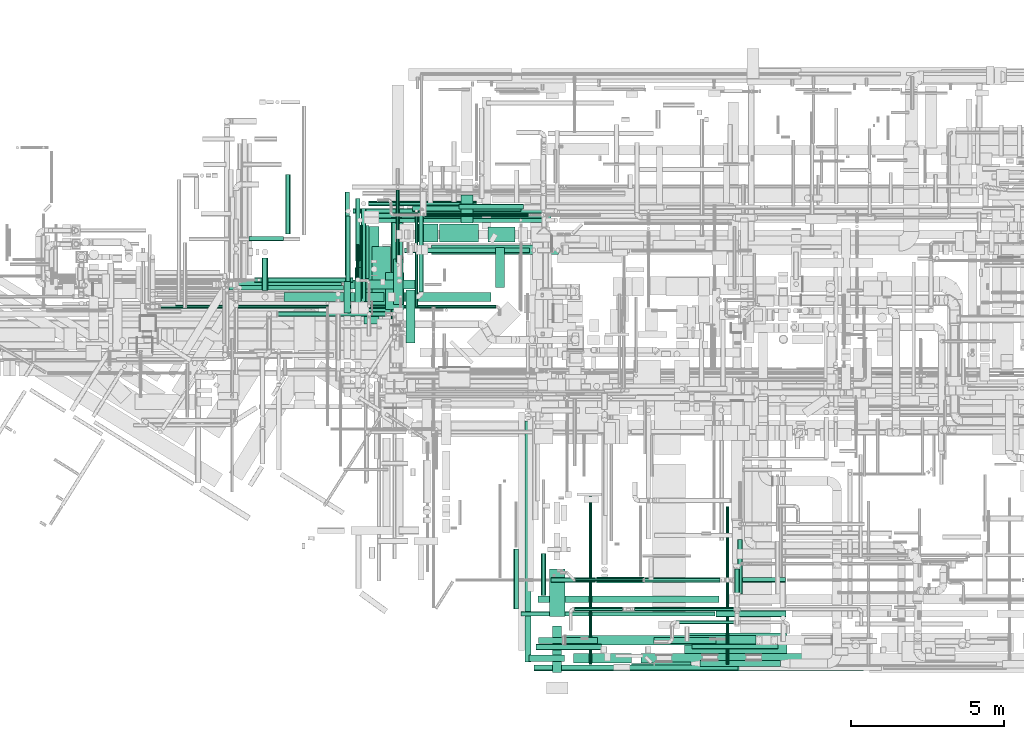
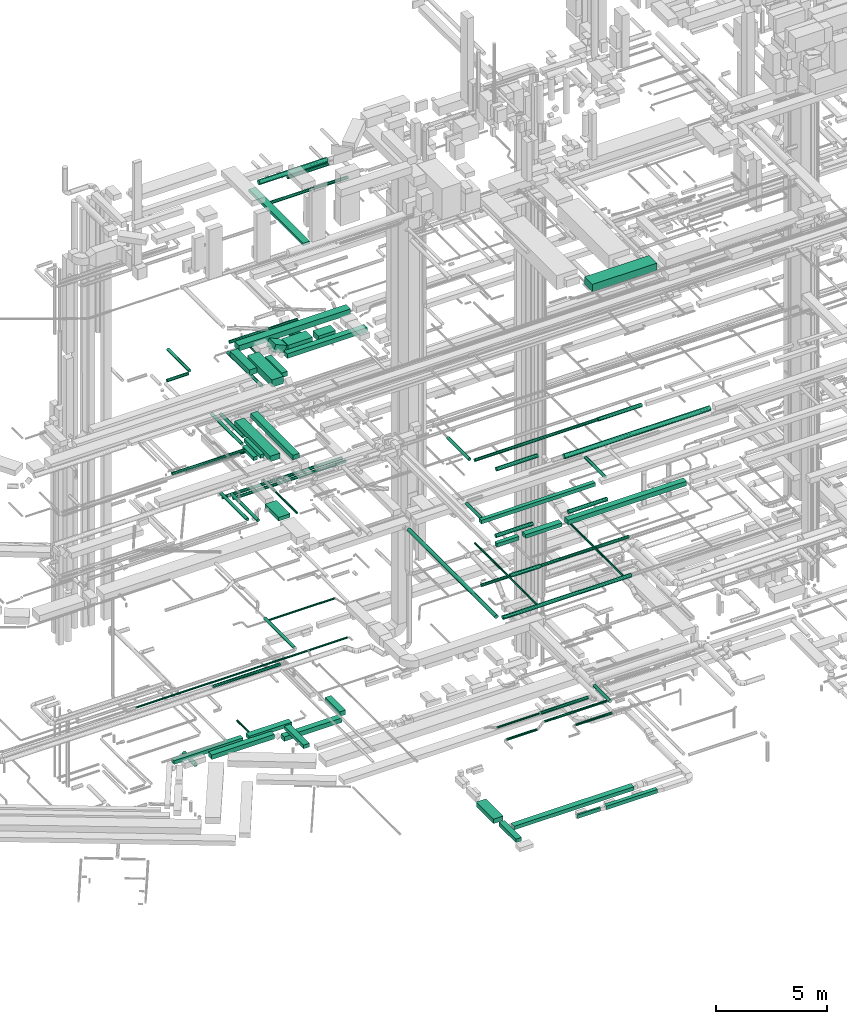
# One storey, part 29 of 337: 77 flow segments.
"""IFC2X3 building model written with IfcOpenShell, lengths in millimetres."""

from ifc_helpers import new_model, entity, si_unit, converted_unit, derived_unit, direction, frame, origin, origin_2d_with_axis, place, context, subcontext, project, spatial, rectangle, circle, extrude, type_object, element, save


model = new_model("IFC2X3")

# Units and contexts
model_context = context("Model", 3, precision=0.01, world=origin(), true_north=direction((6.12303176911189e-17, 1.0)))
body_context = subcontext(model_context, "Body", "Model", "MODEL_VIEW")
ifc_project = project(units=[si_unit("LENGTHUNIT", "METRE", prefix="MILLI"), si_unit("AREAUNIT", "SQUARE_METRE"), si_unit("VOLUMEUNIT", "CUBIC_METRE"), converted_unit("PLANEANGLEUNIT", "DEGREE", entity("IfcRatioMeasure", 0.0174532925199433), si_unit("PLANEANGLEUNIT", "RADIAN"), dimensions=[0, 0, 0, 0, 0, 0, 0]), si_unit("MASSUNIT", "GRAM", prefix="KILO"), derived_unit("MASSDENSITYUNIT", [(si_unit("MASSUNIT", "GRAM", prefix="KILO"), 1), (si_unit("LENGTHUNIT", "METRE"), -3)]), derived_unit("MOMENTOFINERTIAUNIT", [(si_unit("LENGTHUNIT", "METRE"), 4)]), si_unit("TIMEUNIT", "SECOND"), si_unit("FREQUENCYUNIT", "HERTZ"), si_unit("THERMODYNAMICTEMPERATUREUNIT", "DEGREE_CELSIUS"), derived_unit("THERMALTRANSMITTANCEUNIT", [(si_unit("MASSUNIT", "GRAM", prefix="KILO"), 1), (si_unit("THERMODYNAMICTEMPERATUREUNIT", "KELVIN"), -1), (si_unit("TIMEUNIT", "SECOND"), -3)]), derived_unit("VOLUMETRICFLOWRATEUNIT", [(si_unit("LENGTHUNIT", "METRE"), 3), (si_unit("TIMEUNIT", "SECOND"), -1)]), derived_unit("MASSFLOWRATEUNIT", [(si_unit("MASSUNIT", "GRAM", prefix="KILO"), 1), (si_unit("TIMEUNIT", "SECOND"), -1)]), derived_unit("ROTATIONALFREQUENCYUNIT", [(si_unit("TIMEUNIT", "SECOND"), -1)]), si_unit("ELECTRICCURRENTUNIT", "AMPERE"), si_unit("ELECTRICVOLTAGEUNIT", "VOLT"), si_unit("POWERUNIT", "WATT"), si_unit("FORCEUNIT", "NEWTON", prefix="KILO"), si_unit("ILLUMINANCEUNIT", "LUX"), si_unit("LUMINOUSFLUXUNIT", "LUMEN"), si_unit("LUMINOUSINTENSITYUNIT", "CANDELA"), derived_unit("USERDEFINED", [(si_unit("MASSUNIT", "GRAM", prefix="KILO"), -1), (si_unit("LENGTHUNIT", "METRE"), -2), (si_unit("TIMEUNIT", "SECOND"), 3), (si_unit("LUMINOUSFLUXUNIT", "LUMEN"), 1)]), derived_unit("LINEARVELOCITYUNIT", [(si_unit("LENGTHUNIT", "METRE"), 1), (si_unit("TIMEUNIT", "SECOND"), -1)]), si_unit("PRESSUREUNIT", "PASCAL"), derived_unit("USERDEFINED", [(si_unit("LENGTHUNIT", "METRE"), -2), (si_unit("MASSUNIT", "GRAM", prefix="KILO"), 1), (si_unit("TIMEUNIT", "SECOND"), -2)]), derived_unit("LINEARFORCEUNIT", [(si_unit("MASSUNIT", "GRAM", prefix="KILO"), 1), (si_unit("LENGTHUNIT", "METRE"), 1), (si_unit("TIMEUNIT", "SECOND"), -2), (si_unit("LENGTHUNIT", "METRE"), -1)]), derived_unit("PLANARFORCEUNIT", [(si_unit("MASSUNIT", "GRAM", prefix="KILO"), 1), (si_unit("LENGTHUNIT", "METRE"), 1), (si_unit("TIMEUNIT", "SECOND"), -2), (si_unit("LENGTHUNIT", "METRE"), -2)])], contexts=[model_context])

# Site, building, storey
site_placement = place(None, origin())
site = spatial("IfcSite", under=ifc_project, at=site_placement, CompositionType="ELEMENT")
building_placement = place(site_placement, origin())
building = spatial("IfcBuilding", under=site, at=building_placement, CompositionType="ELEMENT")
storey_placement = place(building_placement, origin())
storey = spatial("IfcBuildingStorey", under=building, at=storey_placement, CompositionType="ELEMENT", Elevation=0.0)

# Flow segments
duct_segment_type_1 = type_object("IfcDuctSegmentType", PredefinedType="NOTDEFINED")
flow_segment_1_placement = place(storey_placement, frame((14823.99, 12483.83, -725.0)))
element("IfcFlowSegment", 1, at=flow_segment_1_placement, inside=storey, type_object=duct_segment_type_1, context=body_context, shape_type="SweptSolid", body=[
    extrude(rectangle(XDim=3262.38838163226, YDim=299.999999999999, at=origin_2d_with_axis()), frame((1631.19, 150.0, 0.0), z_axis=(0.0, 0.0, 1.0), x_axis=(-1.0, 0.0, 0.0)), (0.0, 0.0, 1.0), 250.0),
])
flow_segment_2_placement = place(storey_placement, frame((18591.56, 12483.83, -1050.0)))
element("IfcFlowSegment", 2, at=flow_segment_2_placement, inside=storey, type_object=duct_segment_type_1, context=body_context, shape_type="SweptSolid", body=[
    extrude(rectangle(XDim=2988.13225493354, YDim=300.000000000001, at=origin_2d_with_axis()), frame((1494.07, 150.0, 0.0)), (0.0, 0.0, 1.0), 250.0),
])
flow_segment_3_placement = place(storey_placement, frame((21729.69, 12933.83, -1050.0)))
element("IfcFlowSegment", 3, at=flow_segment_3_placement, inside=storey, type_object=duct_segment_type_1, context=body_context, shape_type="SweptSolid", body=[
    extrude(rectangle(XDim=1318.57318, YDim=300.000000000001, at=origin_2d_with_axis()), frame((150.0, 659.29, 0.0), z_axis=(0.0, 0.0, 1.0), x_axis=(0.0, 1.0, 0.0)), (0.0, 0.0, 1.0), 250.0),
])
flow_segment_4_placement = place(storey_placement, frame((13117.47, 12909.08, -650.0)))
element("IfcFlowSegment", 4, at=flow_segment_4_placement, inside=storey, type_object=duct_segment_type_1, context=body_context, shape_type="SweptSolid", body=[
    extrude(rectangle(XDim=3578.96571761756, YDim=249.999999999999, at=origin_2d_with_axis()), frame((1789.48, 125.0, 0.0)), (0.0, 0.0, 1.0), 200.0),
])
flow_segment_5_placement = place(storey_placement, frame((16996.44, 12884.08, -650.0)))
element("IfcFlowSegment", 5, at=flow_segment_5_placement, inside=storey, type_object=duct_segment_type_1, context=body_context, shape_type="SweptSolid", body=[
    extrude(rectangle(XDim=2209.11071214288, YDim=300.000000000001, at=origin_2d_with_axis()), frame((1104.56, 150.0, 0.0)), (0.0, 0.0, 1.0), 200.0),
])
flow_segment_6_placement = place(storey_placement, frame((18805.54, 11120.0, -700.0)))
element("IfcFlowSegment", 6, at=flow_segment_6_placement, inside=storey, type_object=duct_segment_type_1, context=body_context, shape_type="SweptSolid", body=[
    extrude(rectangle(XDim=1744.07623364408, YDim=299.999999999999, at=origin_2d_with_axis()), frame((150.0, 872.04, 0.0), z_axis=(0.0, 0.0, 1.0), x_axis=(0.0, -1.0, 0.0)), (0.0, 0.0, 1.0), 200.0),
])
flow_segment_7_placement = place(storey_placement, frame((28414.6, 548.22, -1000.0)))
element("IfcFlowSegment", 7, at=flow_segment_7_placement, inside=storey, type_object=duct_segment_type_1, context=body_context, shape_type="SweptSolid", body=[
    extrude(rectangle(XDim=2636.45259885726, YDim=200.0, at=origin_2d_with_axis()), frame((1318.23, 100.0, 0.0), z_axis=(0.0, 0.0, 1.0), x_axis=(-1.0, 0.0, 0.0)), (0.0, 0.0, 1.0), 200.0),
])
flow_segment_8_placement = place(storey_placement, frame((26929.6, 598.22, -1000.0)))
element("IfcFlowSegment", 8, at=flow_segment_8_placement, inside=storey, type_object=duct_segment_type_1, context=body_context, shape_type="SweptSolid", body=[
    extrude(rectangle(XDim=1184.99999999994, YDim=100.0, at=origin_2d_with_axis()), frame((592.5, 50.0, 0.0), z_axis=(0.0, 0.0, 1.0), x_axis=(-1.0, 0.0, 0.0)), (0.0, 0.0, 1.0), 200.0),
])
flow_segment_9_placement = place(storey_placement, frame((24026.09, 1257.6, -1000.0)))
element("IfcFlowSegment", 9, at=flow_segment_9_placement, inside=storey, type_object=duct_segment_type_1, context=body_context, shape_type="SweptSolid", body=[
    extrude(rectangle(XDim=6217.49999999999, YDim=300.0, at=origin_2d_with_axis()), frame((3108.75, 150.0, 0.0), z_axis=(0.0, 0.0, 1.0), x_axis=(-1.0, 0.0, 0.0)), (0.0, 0.0, 1.0), 200.0),
])
flow_segment_10_placement = place(storey_placement, frame((23594.4, 348.45, -1000.0)))
element("IfcFlowSegment", 10, at=flow_segment_10_placement, inside=storey, type_object=duct_segment_type_1, context=body_context, shape_type="SweptSolid", body=[
    extrude(rectangle(XDim=1530.86056001301, YDim=300.000000000001, at=origin_2d_with_axis()), frame((150.0, 765.43, 0.0), z_axis=(0.0, 0.0, 1.0), x_axis=(0.0, 1.0, 0.0)), (0.0, 0.0, 1.0), 200.0),
])
flow_segment_11_placement = place(storey_placement, frame((23494.4, 2179.32, -1025.0)))
element("IfcFlowSegment", 11, at=flow_segment_11_placement, inside=storey, type_object=duct_segment_type_1, context=body_context, shape_type="SweptSolid", body=[
    extrude(rectangle(XDim=1551.96199539522, YDim=499.999999999999, at=origin_2d_with_axis()), frame((250.0, 775.98, 0.0), z_axis=(0.0, 0.0, 1.0), x_axis=(0.0, 1.0, 0.0)), (0.0, 0.0, 1.0), 250.0),
])
flow_segment_12_placement = place(storey_placement, frame((18141.81, 12217.88, 11350.0)))
element("IfcFlowSegment", 12, at=flow_segment_12_placement, inside=storey, type_object=duct_segment_type_1, context=body_context, shape_type="SweptSolid", body=[
    extrude(rectangle(XDim=1219.99999999988, YDim=600.0, at=origin_2d_with_axis()), frame((300.0, 610.0, 0.0), z_axis=(0.0, 0.0, 1.0), x_axis=(0.0, 1.0, 0.0)), (0.0, 0.0, 1.0), 199.999999999998),
])
flow_segment_13_placement = place(storey_placement, frame((18345.0, 11290.41, 15200.0)))
element("IfcFlowSegment", 13, at=flow_segment_13_placement, inside=storey, type_object=duct_segment_type_1, context=body_context, shape_type="SweptSolid", body=[
    extrude(rectangle(XDim=3799.59159269873, YDim=350.000000000001, at=origin_2d_with_axis()), frame((175.0, 1899.8, 0.0), z_axis=(0.0, 0.0, 1.0), x_axis=(0.0, -1.0, 0.0)), (0.0, 0.0, 1.0), 249.999999999999),
])
flow_segment_14_placement = place(storey_placement, frame((26482.56, 670.66, 15225.0)))
element("IfcFlowSegment", 14, at=flow_segment_14_placement, inside=storey, type_object=duct_segment_type_1, context=body_context, shape_type="SweptSolid", body=[
    extrude(rectangle(XDim=6158.37166419825, YDim=300.0, at=origin_2d_with_axis()), frame((3079.19, 150.0, 0.0)), (0.0, 0.0, 1.0), 249.999999999999),
])
flow_segment_15_placement = place(storey_placement, frame((17699.48, 12042.03, 18950.0)))
element("IfcFlowSegment", 15, at=flow_segment_15_placement, inside=storey, type_object=duct_segment_type_1, context=body_context, shape_type="SweptSolid", body=[
    extrude(rectangle(XDim=2230.86893254484, YDim=600.0, at=origin_2d_with_axis()), frame((300.0, 1115.43, 0.0), z_axis=(0.0, 0.0, 1.0), x_axis=(0.0, 1.0, 0.0)), (0.0, 0.0, 1.0), 400.0),
])
flow_segment_16_placement = place(storey_placement, frame((19907.87, 14422.9, 18640.0)))
element("IfcFlowSegment", 16, at=flow_segment_16_placement, inside=storey, type_object=duct_segment_type_1, context=body_context, shape_type="SweptSolid", body=[
    extrude(rectangle(XDim=1271.71476357321, YDim=600.0, at=origin_2d_with_axis()), frame((635.86, 300.0, 0.0)), (0.0, 0.0, 1.0), 400.0),
])
flow_segment_17_placement = place(storey_placement, frame((21479.58, 14422.9, 18690.0)))
element("IfcFlowSegment", 17, at=flow_segment_17_placement, inside=storey, type_object=duct_segment_type_1, context=body_context, shape_type="SweptSolid", body=[
    extrude(rectangle(XDim=895.634640732672, YDim=500.000000000001, at=origin_2d_with_axis()), frame((447.82, 250.0, 0.0)), (0.0, 0.0, 1.0), 300.000000000001),
])
flow_segment_18_placement = place(storey_placement, frame((19116.68, 14422.9, 18686.6)))
element("IfcFlowSegment", 18, at=flow_segment_18_placement, inside=storey, type_object=duct_segment_type_1, context=body_context, shape_type="SweptSolid", body=[
    extrude(rectangle(XDim=400.000000000005, YDim=600.0, at=origin_2d_with_axis()), frame((80.56, 300.0, 433.75), z_axis=(0.915282031512425, 0.0, -0.402813608000634), x_axis=(0.402813608000634, 0.0, 0.915282031512425)), (0.0, 0.0, 1.0), 622.364534896963),
])
flow_segment_19_placement = place(storey_placement, frame((17200.26, 13228.06, 19050.0)))
element("IfcFlowSegment", 19, at=flow_segment_19_placement, inside=storey, type_object=duct_segment_type_1, context=body_context, shape_type="SweptSolid", body=[
    extrude(rectangle(XDim=1731.93545585369, YDim=400.0, at=origin_2d_with_axis()), frame((200.0, 865.97, 0.0), z_axis=(0.0, 0.0, 1.0), x_axis=(0.0, 1.0, 0.0)), (0.0, 0.0, 1.0), 300.000000000001),
])
flow_segment_20_placement = place(storey_placement, frame((17750.26, 15110.0, 19050.0)))
element("IfcFlowSegment", 20, at=flow_segment_20_placement, inside=storey, type_object=duct_segment_type_1, context=body_context, shape_type="SweptSolid", body=[
    extrude(rectangle(XDim=5786.57062510331, YDim=400.0, at=origin_2d_with_axis()), frame((2893.29, 200.0, 0.0)), (0.0, 0.0, 1.0), 300.000000000001),
])
flow_segment_21_placement = place(storey_placement, frame((18399.92, 12384.44, 19025.0)))
element("IfcFlowSegment", 21, at=flow_segment_21_placement, inside=storey, type_object=duct_segment_type_1, context=body_context, shape_type="SweptSolid", body=[
    extrude(rectangle(XDim=1491.0912703474, YDim=299.999999999999, at=origin_2d_with_axis()), frame((150.0, 745.55, 0.0), z_axis=(0.0, 0.0, 1.0), x_axis=(0.0, -1.0, 0.0)), (0.0, 0.0, 1.0), 249.999999999999),
])
flow_segment_22_placement = place(storey_placement, frame((20595.28, 15042.9, 18640.58)))
element("IfcFlowSegment", 22, at=flow_segment_22_placement, inside=storey, type_object=duct_segment_type_1, context=body_context, shape_type="SweptSolid", body=[
    extrude(rectangle(XDim=925.523936282975, YDim=400.0, at=origin_2d_with_axis()), frame((200.0, 462.76, 0.0), z_axis=(0.0, 0.0, 1.0), x_axis=(0.0, 1.0, 0.0)), (0.0, 0.0, 1.0), 300.000000000001),
])
flow_segment_23_placement = place(storey_placement, frame((19636.61, 14025.53, 18650.0)))
element("IfcFlowSegment", 23, at=flow_segment_23_placement, inside=storey, type_object=duct_segment_type_1, context=body_context, shape_type="SweptSolid", body=[
    extrude(rectangle(XDim=4154.30351941165, YDim=299.999999999999, at=origin_2d_with_axis()), frame((2077.15, 150.0, 0.0)), (0.0, 0.0, 1.0), 249.999999999999),
])
flow_segment_24_placement = place(storey_placement, frame((24282.56, 670.66, 15250.0)))
element("IfcFlowSegment", 24, at=flow_segment_24_placement, inside=storey, type_object=duct_segment_type_1, context=body_context, shape_type="SweptSolid", body=[
    extrude(rectangle(XDim=1900.0, YDim=300.0, at=origin_2d_with_axis()), frame((950.0, 150.0, 0.0), z_axis=(0.0, 0.0, 1.0), x_axis=(-1.0, 0.0, 0.0)), (0.0, 0.0, 1.0), 200.000000000002),
])
flow_segment_25_placement = place(storey_placement, frame((23127.55, 2649.02, 15250.0)))
element("IfcFlowSegment", 25, at=flow_segment_25_placement, inside=storey, type_object=duct_segment_type_1, context=body_context, shape_type="SweptSolid", body=[
    extrude(rectangle(XDim=5911.24235509843, YDim=200.0, at=origin_2d_with_axis()), frame((2955.62, 100.0, 0.0), z_axis=(0.0, 0.0, 1.0), x_axis=(-1.0, 0.0, 0.0)), (0.0, 0.0, 1.0), 200.000000000002),
])
flow_segment_26_placement = place(storey_placement, frame((17130.0, 12111.81, 15200.0)))
element("IfcFlowSegment", 26, at=flow_segment_26_placement, inside=storey, type_object=duct_segment_type_1, context=body_context, shape_type="SweptSolid", body=[
    extrude(rectangle(XDim=1488.18924345159, YDim=200.0, at=origin_2d_with_axis()), frame((100.0, 744.09, 0.0), z_axis=(0.0, 0.0, 1.0), x_axis=(0.0, -1.0, 0.0)), (0.0, 0.0, 1.0), 199.999999999998),
])
flow_segment_27_placement = place(storey_placement, frame((16784.94, 12111.81, 15200.0)))
element("IfcFlowSegment", 27, at=flow_segment_27_placement, inside=storey, type_object=duct_segment_type_1, context=body_context, shape_type="SweptSolid", body=[
    extrude(rectangle(XDim=1016.44660940674, YDim=200.0, at=origin_2d_with_axis()), frame((100.0, 508.22, 0.0), z_axis=(0.0, 0.0, 1.0), x_axis=(0.0, -1.0, 0.0)), (0.0, 0.0, 1.0), 199.999999999998),
])
flow_segment_28_placement = place(storey_placement, frame((22832.56, 720.66, 15250.0)))
element("IfcFlowSegment", 28, at=flow_segment_28_placement, inside=storey, type_object=duct_segment_type_1, context=body_context, shape_type="SweptSolid", body=[
    extrude(rectangle(XDim=1149.99999999995, YDim=200.0, at=origin_2d_with_axis()), frame((575.0, 100.0, 0.0)), (0.0, 0.0, 1.0), 200.000000000002),
])
flow_segment_29_placement = place(storey_placement, frame((17425.0, 11739.53, 15150.0)))
element("IfcFlowSegment", 29, at=flow_segment_29_placement, inside=storey, type_object=duct_segment_type_1, context=body_context, shape_type="SweptSolid", body=[
    extrude(rectangle(XDim=3189.7981749749, YDim=499.999999999999, at=origin_2d_with_axis()), frame((250.0, 1594.9, 0.0), z_axis=(0.0, 0.0, 1.0), x_axis=(0.0, -1.0, 0.0)), (0.0, 0.0, 1.0), 300.000000000001),
])
flow_segment_30_placement = place(storey_placement, frame((18321.73, 10324.63, 27525.0)))
element("IfcFlowSegment", 30, at=flow_segment_30_placement, inside=storey, type_object=duct_segment_type_1, context=body_context, shape_type="SweptSolid", body=[
    extrude(rectangle(XDim=4900.40194846606, YDim=350.000000000001, at=origin_2d_with_axis()), frame((175.0, 2450.2, 0.0), z_axis=(0.0, 0.0, 1.0), x_axis=(0.0, -1.0, 0.0)), (0.0, 0.0, 1.0), 150.000000000001),
])
flow_segment_31_placement = place(storey_placement, frame((27900.62, 944.06, 27350.0)))
element("IfcFlowSegment", 31, at=flow_segment_31_placement, inside=storey, type_object=duct_segment_type_1, context=body_context, shape_type="SweptSolid", body=[
    extrude(rectangle(XDim=3350.88242033331, YDim=700.0, at=origin_2d_with_axis()), frame((1675.44, 350.0, 0.0), z_axis=(0.0, 0.0, 1.0), x_axis=(-1.0, 0.0, 0.0)), (0.0, 0.0, 1.0), 399.999999999996),
])
duct_segment_type_2 = type_object("IfcDuctSegmentType", PredefinedType="NOTDEFINED")
flow_segment_32_placement = place(storey_placement, frame((14097.4, 12833.83, -1101.6)))
element("IfcFlowSegment", 32, at=flow_segment_32_placement, inside=storey, type_object=duct_segment_type_2, context=body_context, shape_type="SweptSolid", body=[
    extrude(circle(Radius=100.0, at=origin_2d_with_axis()), frame((101.6, 0.0, 101.6), z_axis=(0.0, 1.0, 0.0), x_axis=(-1.0, 0.0, 0.0)), (0.0, 0.0, 1.0), 1067.14808000005),
])
flow_segment_33_placement = place(storey_placement, frame((17164.34, 13204.08, -601.6)))
element("IfcFlowSegment", 33, at=flow_segment_33_placement, inside=storey, type_object=duct_segment_type_2, context=body_context, shape_type="SweptSolid", body=[
    extrude(circle(Radius=50.0, at=origin_2d_with_axis()), frame((51.6, 0.0, 51.6), z_axis=(0.0, 1.0, 0.0), x_axis=(1.0, 0.0, 0.0)), (0.0, 0.0, 1.0), 1142.54489678344),
])
flow_segment_34_placement = place(storey_placement, frame((22991.81, 398.42, 11368.4)))
element("IfcFlowSegment", 34, at=flow_segment_34_placement, inside=storey, type_object=duct_segment_type_2, context=body_context, shape_type="SweptSolid", body=[
    extrude(circle(Radius=100.0, at=origin_2d_with_axis()), frame((0.0, 101.6, 101.6), z_axis=(1.0, 0.0, 0.0), x_axis=(0.0, -1.0, 0.0)), (0.0, 0.0, 1.0), 6660.95595819992),
])
flow_segment_35_placement = place(storey_placement, frame((25037.3, 3278.95, 11198.4)))
element("IfcFlowSegment", 35, at=flow_segment_35_placement, inside=storey, type_object=duct_segment_type_2, context=body_context, shape_type="SweptSolid", body=[
    extrude(circle(Radius=100.0, at=origin_2d_with_axis()), frame((0.0, 101.6, 101.6), z_axis=(1.0, 0.0, 0.0), x_axis=(0.0, 1.0, 0.0)), (0.0, 0.0, 1.0), 1570.00000000001),
])
flow_segment_36_placement = place(storey_placement, frame((23537.3, 3298.95, 11218.4)))
element("IfcFlowSegment", 36, at=flow_segment_36_placement, inside=storey, type_object=duct_segment_type_2, context=body_context, shape_type="SweptSolid", body=[
    extrude(circle(Radius=80.0, at=origin_2d_with_axis()), frame((0.0, 81.6, 81.6), z_axis=(1.0, 0.0, 0.0), x_axis=(0.0, -1.0, 0.0)), (0.0, 0.0, 1.0), 1459.99999999999),
])
flow_segment_37_placement = place(storey_placement, frame((26647.3, 3298.95, 11218.4)))
element("IfcFlowSegment", 37, at=flow_segment_37_placement, inside=storey, type_object=duct_segment_type_2, context=body_context, shape_type="SweptSolid", body=[
    extrude(circle(Radius=80.0, at=origin_2d_with_axis()), frame((0.0, 81.6, 81.6), z_axis=(1.0, 0.0, 0.0), x_axis=(0.0, 1.0, 0.0)), (0.0, 0.0, 1.0), 4555.0),
])
flow_segment_38_placement = place(storey_placement, frame((24785.12, 620.02, 11418.4)))
element("IfcFlowSegment", 38, at=flow_segment_38_placement, inside=storey, type_object=duct_segment_type_2, context=body_context, shape_type="SweptSolid", body=[
    extrude(circle(Radius=50.0, at=origin_2d_with_axis()), frame((51.6, 0.0, 51.6), z_axis=(0.0, 1.0, 0.0), x_axis=(1.0, 0.0, 0.0)), (0.0, 0.0, 1.0), 5557.86105600282),
])
flow_segment_39_placement = place(storey_placement, frame((29261.83, 620.02, 11418.4)))
element("IfcFlowSegment", 39, at=flow_segment_39_placement, inside=storey, type_object=duct_segment_type_2, context=body_context, shape_type="SweptSolid", body=[
    extrude(circle(Radius=50.0, at=origin_2d_with_axis()), frame((51.6, 0.0, 51.6), z_axis=(0.0, 1.0, 0.0), x_axis=(1.0, 0.0, 0.0)), (0.0, 0.0, 1.0), 5157.86105600283),
])
flow_segment_40_placement = place(storey_placement, frame((22690.22, 700.02, 11368.4)))
element("IfcFlowSegment", 40, at=flow_segment_40_placement, inside=storey, type_object=duct_segment_type_2, context=body_context, shape_type="SweptSolid", body=[
    extrude(circle(Radius=100.0, at=origin_2d_with_axis()), frame((101.6, 0.0, 101.6), z_axis=(0.0, 1.0, 0.0), x_axis=(1.0, 0.0, 0.0)), (0.0, 0.0, 1.0), 7870.10119134039),
])
flow_segment_41_placement = place(storey_placement, frame((10782.78, 12258.76, 3598.4)))
element("IfcFlowSegment", 41, at=flow_segment_41_placement, inside=storey, type_object=duct_segment_type_2, context=body_context, shape_type="SweptSolid", body=[
    extrude(circle(Radius=50.0, at=origin_2d_with_axis()), frame((0.0, 51.6, 51.6), z_axis=(1.0, 0.0, 0.0), x_axis=(0.0, -1.0, 0.0)), (0.0, 0.0, 1.0), 10972.389068712),
])
flow_segment_42_placement = place(storey_placement, frame((16829.74, 12874.35, 11388.41)))
element("IfcFlowSegment", 42, at=flow_segment_42_placement, inside=storey, type_object=duct_segment_type_2, context=body_context, shape_type="SweptSolid", body=[
    extrude(circle(Radius=80.0, at=origin_2d_with_axis()), frame((81.6, 0.0, 81.6), z_axis=(0.0, 1.0, 0.0), x_axis=(-1.0, 0.0, 0.0)), (0.0, 0.0, 1.0), 2400.49613498055),
])
flow_segment_43_placement = place(storey_placement, frame((17215.73, 12585.69, 11388.4)))
element("IfcFlowSegment", 43, at=flow_segment_43_placement, inside=storey, type_object=duct_segment_type_2, context=body_context, shape_type="SweptSolid", body=[
    extrude(circle(Radius=80.0, at=origin_2d_with_axis()), frame((81.6, 0.0, 81.6), z_axis=(0.0, 1.0, 0.0), x_axis=(-1.0, 0.0, 0.0)), (0.0, 0.0, 1.0), 2392.59934815096),
])
flow_segment_44_placement = place(storey_placement, frame((17457.33, 15056.69, 10988.4)))
element("IfcFlowSegment", 44, at=flow_segment_44_placement, inside=storey, type_object=duct_segment_type_2, context=body_context, shape_type="SweptSolid", body=[
    extrude(circle(Radius=80.0, at=origin_2d_with_axis()), frame((0.0, 81.6, 81.6), z_axis=(1.0, 0.0, 0.0), x_axis=(0.0, 1.0, 0.0)), (0.0, 0.0, 1.0), 5854.44583002029),
])
flow_segment_45_placement = place(storey_placement, frame((17071.33, 15353.25, 10988.4)))
element("IfcFlowSegment", 45, at=flow_segment_45_placement, inside=storey, type_object=duct_segment_type_2, context=body_context, shape_type="SweptSolid", body=[
    extrude(circle(Radius=80.0, at=origin_2d_with_axis()), frame((0.0, 81.6, 81.6), z_axis=(1.0, 0.0, 0.0), x_axis=(0.0, -1.0, 0.0)), (0.0, 0.0, 1.0), 6214.44583002034),
])
flow_segment_46_placement = place(storey_placement, frame((19089.97, 12298.29, 11348.4)))
element("IfcFlowSegment", 46, at=flow_segment_46_placement, inside=storey, type_object=duct_segment_type_2, context=body_context, shape_type="SweptSolid", body=[
    extrude(circle(Radius=50.0, at=origin_2d_with_axis()), frame((51.6, 0.0, 51.6), z_axis=(0.0, 1.0, 0.0), x_axis=(1.0, 0.0, 0.0)), (0.0, 0.0, 1.0), 3036.55942831079),
])
flow_segment_47_placement = place(storey_placement, frame((14624.1, 11992.94, 3518.4)))
element("IfcFlowSegment", 47, at=flow_segment_47_placement, inside=storey, type_object=duct_segment_type_2, context=body_context, shape_type="SweptSolid", body=[
    extrude(circle(Radius=80.0, at=origin_2d_with_axis()), frame((0.0, 81.6, 81.6), z_axis=(1.0, 0.0, 0.0), x_axis=(0.0, -1.0, 0.0)), (0.0, 0.0, 1.0), 3504.99999999999),
])
flow_segment_48_placement = place(storey_placement, frame((19223.1, 12797.83, 3568.4)))
element("IfcFlowSegment", 48, at=flow_segment_48_placement, inside=storey, type_object=duct_segment_type_2, context=body_context, shape_type="SweptSolid", body=[
    extrude(circle(Radius=80.0, at=origin_2d_with_axis()), frame((81.6, 0.0, 81.6), z_axis=(0.0, 1.0, 0.0), x_axis=(1.0, 0.0, 0.0)), (0.0, 0.0, 1.0), 2665.74999999999),
])
flow_segment_49_placement = place(storey_placement, frame((19404.69, 15264.53, 3548.4)))
element("IfcFlowSegment", 49, at=flow_segment_49_placement, inside=storey, type_object=duct_segment_type_2, context=body_context, shape_type="SweptSolid", body=[
    extrude(circle(Radius=50.0, at=origin_2d_with_axis()), frame((0.0, 51.6, 51.6), z_axis=(1.0, 0.0, 0.0), x_axis=(0.0, -1.0, 0.0)), (0.0, 0.0, 1.0), 3408.57864376268),
])
flow_segment_50_placement = place(storey_placement, frame((29544.16, 2319.25, 3368.4)))
element("IfcFlowSegment", 50, at=flow_segment_50_placement, inside=storey, type_object=duct_segment_type_2, context=body_context, shape_type="SweptSolid", body=[
    extrude(circle(Radius=80.0, at=origin_2d_with_axis()), frame((81.6, 0.0, 81.6), z_axis=(0.0, 1.0, 0.0), x_axis=(-1.0, 0.0, 0.0)), (0.0, 0.0, 1.0), 1424.99999999999),
])
flow_segment_51_placement = place(storey_placement, frame((24313.21, 2368.04, 3085.9)))
element("IfcFlowSegment", 51, at=flow_segment_51_placement, inside=storey, type_object=duct_segment_type_2, context=body_context, shape_type="SweptSolid", body=[
    extrude(circle(Radius=62.5, at=origin_2d_with_axis()), frame((0.0, 64.1, 64.1), z_axis=(1.0, 0.0, 0.0), x_axis=(0.0, 1.0, 0.0)), (0.0, 0.0, 1.0), 1560.77443126669),
])
flow_segment_52_placement = place(storey_placement, frame((26277.54, 2368.04, 3385.9)))
element("IfcFlowSegment", 52, at=flow_segment_52_placement, inside=storey, type_object=duct_segment_type_2, context=body_context, shape_type="SweptSolid", body=[
    extrude(circle(Radius=62.5, at=origin_2d_with_axis()), frame((0.0, 64.1, 64.1), z_axis=(1.0, 0.0, 0.0), x_axis=(0.0, 1.0, 0.0)), (0.0, 0.0, 1.0), 3248.22330470333),
])
flow_segment_53_placement = place(storey_placement, frame((24346.88, 3324.11, 3168.4)))
element("IfcFlowSegment", 53, at=flow_segment_53_placement, inside=storey, type_object=duct_segment_type_2, context=body_context, shape_type="SweptSolid", body=[
    extrude(circle(Radius=50.0, at=origin_2d_with_axis()), frame((0.0, 51.6, 51.6), z_axis=(1.0, 0.0, 0.0), x_axis=(0.0, 1.0, 0.0)), (0.0, 0.0, 1.0), 2198.57864376269),
])
flow_segment_54_placement = place(storey_placement, frame((26605.46, 3294.11, 3138.4)))
element("IfcFlowSegment", 54, at=flow_segment_54_placement, inside=storey, type_object=duct_segment_type_2, context=body_context, shape_type="SweptSolid", body=[
    extrude(circle(Radius=80.0, at=origin_2d_with_axis()), frame((0.0, 81.6, 81.6), z_axis=(1.0, 0.0, 0.0), x_axis=(0.0, -1.0, 0.0)), (0.0, 0.0, 1.0), 2470.80576394719),
])
flow_segment_55_placement = place(storey_placement, frame((27624.02, 1931.61, 2985.9)))
element("IfcFlowSegment", 55, at=flow_segment_55_placement, inside=storey, type_object=duct_segment_type_2, context=body_context, shape_type="SweptSolid", body=[
    extrude(circle(Radius=62.5, at=origin_2d_with_axis()), frame((0.0, 64.1, 64.1), z_axis=(1.0, 0.0, 0.0), x_axis=(0.0, -1.0, 0.0)), (0.0, 0.0, 1.0), 1901.20165724076),
])
flow_segment_56_placement = place(storey_placement, frame((13018.32, 12848.4, 15218.4)))
element("IfcFlowSegment", 56, at=flow_segment_56_placement, inside=storey, type_object=duct_segment_type_2, context=body_context, shape_type="SweptSolid", body=[
    extrude(circle(Radius=80.0, at=origin_2d_with_axis()), frame((0.0, 81.6, 81.6), z_axis=(1.0, 0.0, 0.0), x_axis=(0.0, -1.0, 0.0)), (0.0, 0.0, 1.0), 3746.62833580182),
])
flow_segment_57_placement = place(storey_placement, frame((13852.61, 13108.4, 14918.4)))
element("IfcFlowSegment", 57, at=flow_segment_57_placement, inside=storey, type_object=duct_segment_type_2, context=body_context, shape_type="SweptSolid", body=[
    extrude(circle(Radius=80.0, at=origin_2d_with_axis()), frame((0.0, 81.6, 81.6), z_axis=(1.0, 0.0, 0.0), x_axis=(0.0, -1.0, 0.0)), (0.0, 0.0, 1.0), 3216.60473714322),
])
flow_segment_58_placement = place(storey_placement, frame((17148.4, 13800.0, 15268.4)))
element("IfcFlowSegment", 58, at=flow_segment_58_placement, inside=storey, type_object=duct_segment_type_2, context=body_context, shape_type="SweptSolid", body=[
    extrude(circle(Radius=80.0, at=origin_2d_with_axis()), frame((81.6, 0.0, 81.6), z_axis=(0.0, 1.0, 0.0), x_axis=(-1.0, 0.0, 0.0)), (0.0, 0.0, 1.0), 2049.29999999997),
])
flow_segment_59_placement = place(storey_placement, frame((16803.35, 13328.26, 15268.4)))
element("IfcFlowSegment", 59, at=flow_segment_59_placement, inside=storey, type_object=duct_segment_type_2, context=body_context, shape_type="SweptSolid", body=[
    extrude(circle(Radius=80.0, at=origin_2d_with_axis()), frame((81.6, 0.0, 81.6), z_axis=(0.0, 1.0, 0.0), x_axis=(-1.0, 0.0, 0.0)), (0.0, 0.0, 1.0), 2731.00000000002),
])
flow_segment_60_placement = place(storey_placement, frame((13670.96, 14451.28, 19138.4)))
element("IfcFlowSegment", 60, at=flow_segment_60_placement, inside=storey, type_object=duct_segment_type_2, context=body_context, shape_type="SweptSolid", body=[
    extrude(circle(Radius=80.0, at=origin_2d_with_axis()), frame((0.0, 81.6, 81.6), z_axis=(1.0, 0.0, 0.0), x_axis=(0.0, -1.0, 0.0)), (0.0, 0.0, 1.0), 1122.50000000002),
])
flow_segment_61_placement = place(storey_placement, frame((14871.87, 14692.88, 19138.4)))
element("IfcFlowSegment", 61, at=flow_segment_61_placement, inside=storey, type_object=duct_segment_type_2, context=body_context, shape_type="SweptSolid", body=[
    extrude(circle(Radius=80.0, at=origin_2d_with_axis()), frame((81.6, 0.0, 81.6), z_axis=(0.0, 1.0, 0.0), x_axis=(1.0, 0.0, 0.0)), (0.0, 0.0, 1.0), 1932.49999999999),
])
flow_segment_62_placement = place(storey_placement, frame((28945.22, 2174.72, 19073.4)))
element("IfcFlowSegment", 62, at=flow_segment_62_placement, inside=storey, type_object=duct_segment_type_2, context=body_context, shape_type="SweptSolid", body=[
    extrude(circle(Radius=100.0, at=origin_2d_with_axis()), frame((0.0, 101.6, 101.6), z_axis=(1.0, 0.0, 0.0), x_axis=(0.0, 1.0, 0.0)), (0.0, 0.0, 1.0), 2280.0),
])
flow_segment_63_placement = place(storey_placement, frame((22561.78, 2194.72, 19093.4)))
element("IfcFlowSegment", 63, at=flow_segment_63_placement, inside=storey, type_object=duct_segment_type_2, context=body_context, shape_type="SweptSolid", body=[
    extrude(circle(Radius=80.0, at=origin_2d_with_axis()), frame((0.0, 81.6, 81.6), z_axis=(1.0, 0.0, 0.0), x_axis=(0.0, 1.0, 0.0)), (0.0, 0.0, 1.0), 6343.43750000002),
])
flow_segment_64_placement = place(storey_placement, frame((22320.19, 2436.32, 19093.4)))
element("IfcFlowSegment", 64, at=flow_segment_64_placement, inside=storey, type_object=duct_segment_type_2, context=body_context, shape_type="SweptSolid", body=[
    extrude(circle(Radius=80.0, at=origin_2d_with_axis()), frame((81.6, 0.0, 81.6), z_axis=(0.0, 1.0, 0.0), x_axis=(1.0, 0.0, 0.0)), (0.0, 0.0, 1.0), 1952.50000000001),
])
flow_segment_65_placement = place(storey_placement, frame((17338.9, 12487.41, 18768.4)))
element("IfcFlowSegment", 65, at=flow_segment_65_placement, inside=storey, type_object=duct_segment_type_2, context=body_context, shape_type="SweptSolid", body=[
    extrude(circle(Radius=80.0, at=origin_2d_with_axis()), frame((81.6, 0.0, 81.6), z_axis=(0.0, 1.0, 0.0), x_axis=(-1.0, 0.0, 0.0)), (0.0, 0.0, 1.0), 3033.9983929175),
])
flow_segment_66_placement = place(storey_placement, frame((17580.49, 15599.81, 19188.4)))
element("IfcFlowSegment", 66, at=flow_segment_66_placement, inside=storey, type_object=duct_segment_type_2, context=body_context, shape_type="SweptSolid", body=[
    extrude(circle(Radius=80.0, at=origin_2d_with_axis()), frame((0.0, 81.6, 81.6), z_axis=(1.0, 0.0, 0.0), x_axis=(0.0, -1.0, 0.0)), (0.0, 0.0, 1.0), 3534.375),
])
flow_segment_67_placement = place(storey_placement, frame((26169.73, 399.22, 19048.4)))
element("IfcFlowSegment", 67, at=flow_segment_67_placement, inside=storey, type_object=duct_segment_type_2, context=body_context, shape_type="SweptSolid", body=[
    extrude(circle(Radius=125.0, at=origin_2d_with_axis()), frame((0.0, 126.6, 126.6), z_axis=(1.0, 0.0, 0.0), x_axis=(0.0, 1.0, 0.0)), (0.0, 0.0, 1.0), 7587.5),
])
flow_segment_68_placement = place(storey_placement, frame((23047.23, 1081.72, 19073.4)))
element("IfcFlowSegment", 68, at=flow_segment_68_placement, inside=storey, type_object=duct_segment_type_2, context=body_context, shape_type="SweptSolid", body=[
    extrude(circle(Radius=100.0, at=origin_2d_with_axis()), frame((0.0, 101.6, 101.6), z_axis=(1.0, 0.0, 0.0), x_axis=(0.0, 1.0, 0.0)), (0.0, 0.0, 1.0), 2142.81250000001),
])
flow_segment_69_placement = place(storey_placement, frame((29642.93, 2919.02, 15268.4)))
element("IfcFlowSegment", 69, at=flow_segment_69_placement, inside=storey, type_object=duct_segment_type_2, context=body_context, shape_type="SweptSolid", body=[
    extrude(circle(Radius=80.0, at=origin_2d_with_axis()), frame((81.6, 0.0, 81.6), z_axis=(0.0, 1.0, 0.0), x_axis=(-1.0, 0.0, 0.0)), (0.0, 0.0, 1.0), 1791.42135623734),
])
flow_segment_70_placement = place(storey_placement, frame((26913.45, 1300.8, 15248.4)))
element("IfcFlowSegment", 70, at=flow_segment_70_placement, inside=storey, type_object=duct_segment_type_2, context=body_context, shape_type="SweptSolid", body=[
    extrude(circle(Radius=100.0, at=origin_2d_with_axis()), frame((0.0, 101.6, 101.6), z_axis=(1.0, 0.0, 0.0), x_axis=(0.0, 1.0, 0.0)), (0.0, 0.0, 1.0), 2020.00000000004),
])
flow_segment_71_placement = place(storey_placement, frame((18482.93, 13781.21, 18748.4)))
element("IfcFlowSegment", 71, at=flow_segment_71_placement, inside=storey, type_object=duct_segment_type_2, context=body_context, shape_type="SweptSolid", body=[
    extrude(circle(Radius=50.0, at=origin_2d_with_axis()), frame((51.6, 0.0, 51.6), z_axis=(0.0, 1.0, 0.0), x_axis=(-1.0, 0.0, 0.0)), (0.0, 0.0, 1.0), 2345.0),
])
flow_segment_72_placement = place(storey_placement, frame((23214.23, 2869.02, 15268.4)))
element("IfcFlowSegment", 72, at=flow_segment_72_placement, inside=storey, type_object=duct_segment_type_2, context=body_context, shape_type="SweptSolid", body=[
    extrude(circle(Radius=80.0, at=origin_2d_with_axis()), frame((81.6, 0.0, 81.6), z_axis=(0.0, 1.0, 0.0), x_axis=(-1.0, 0.0, 0.0)), (0.0, 0.0, 1.0), 1381.4213562372),
])
flow_segment_73_placement = place(storey_placement, frame((23142.56, 1300.8, 15248.4)))
element("IfcFlowSegment", 73, at=flow_segment_73_placement, inside=storey, type_object=duct_segment_type_2, context=body_context, shape_type="SweptSolid", body=[
    extrude(circle(Radius=100.0, at=origin_2d_with_axis()), frame((0.0, 101.6, 101.6), z_axis=(1.0, 0.0, 0.0), x_axis=(0.0, -1.0, 0.0)), (0.0, 0.0, 1.0), 1926.38407764754),
])
flow_segment_74_placement = place(storey_placement, frame((19021.73, 15423.43, 27473.4)))
element("IfcFlowSegment", 74, at=flow_segment_74_placement, inside=storey, type_object=duct_segment_type_2, context=body_context, shape_type="SweptSolid", body=[
    extrude(circle(Radius=125.0, at=origin_2d_with_axis()), frame((0.0, 126.6, 126.6), z_axis=(1.0, 0.0, 0.0), x_axis=(0.0, -1.0, 0.0)), (0.0, 0.0, 1.0), 3541.49022532525),
])
flow_segment_75_placement = place(storey_placement, frame((20534.92, 15500.39, 27238.4)))
element("IfcFlowSegment", 75, at=flow_segment_75_placement, inside=storey, type_object=duct_segment_type_2, context=body_context, shape_type="SweptSolid", body=[
    extrude(circle(Radius=80.0, at=origin_2d_with_axis()), frame((0.0, 81.6, 81.6), z_axis=(1.0, 0.0, 0.0), x_axis=(0.0, 1.0, 0.0)), (0.0, 0.0, 1.0), 2107.5),
])
flow_segment_76_placement = place(storey_placement, frame((28153.75, 1119.91, 27138.4)))
element("IfcFlowSegment", 76, at=flow_segment_76_placement, inside=storey, type_object=duct_segment_type_2, context=body_context, shape_type="SweptSolid", body=[
    extrude(circle(Radius=80.0, at=origin_2d_with_axis()), frame((0.0, 81.6, 81.6), z_axis=(1.0, 0.0, 0.0), x_axis=(0.0, 1.0, 0.0)), (0.0, 0.0, 1.0), 2816.75264562718),
])
flow_segment_77_placement = place(storey_placement, frame((18751.73, 14073.37, 27318.4)))
element("IfcFlowSegment", 77, at=flow_segment_77_placement, inside=storey, type_object=duct_segment_type_2, context=body_context, shape_type="SweptSolid", body=[
    extrude(circle(Radius=80.0, at=origin_2d_with_axis()), frame((0.0, 81.6, 81.6), z_axis=(1.0, 0.0, 0.0), x_axis=(0.0, -1.0, 0.0)), (0.0, 0.0, 1.0), 4087.12667987769),
])

save(model, "model.ifc")
